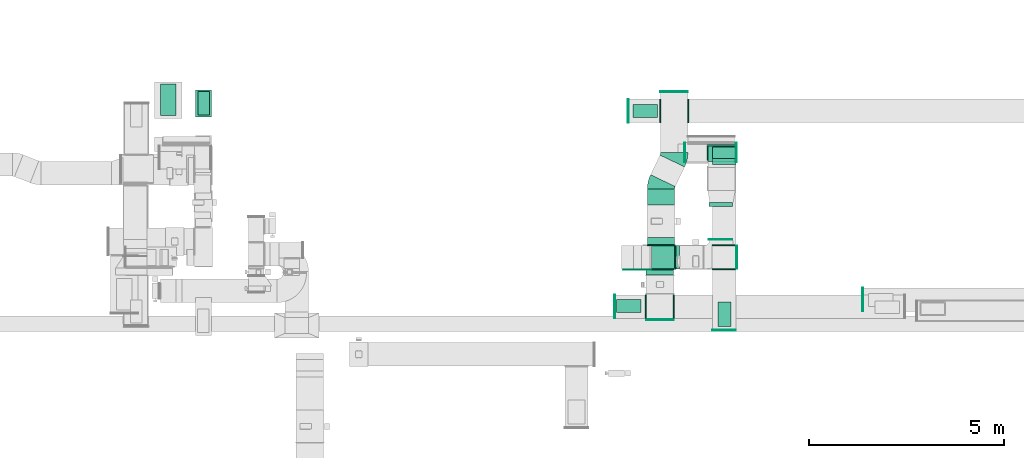
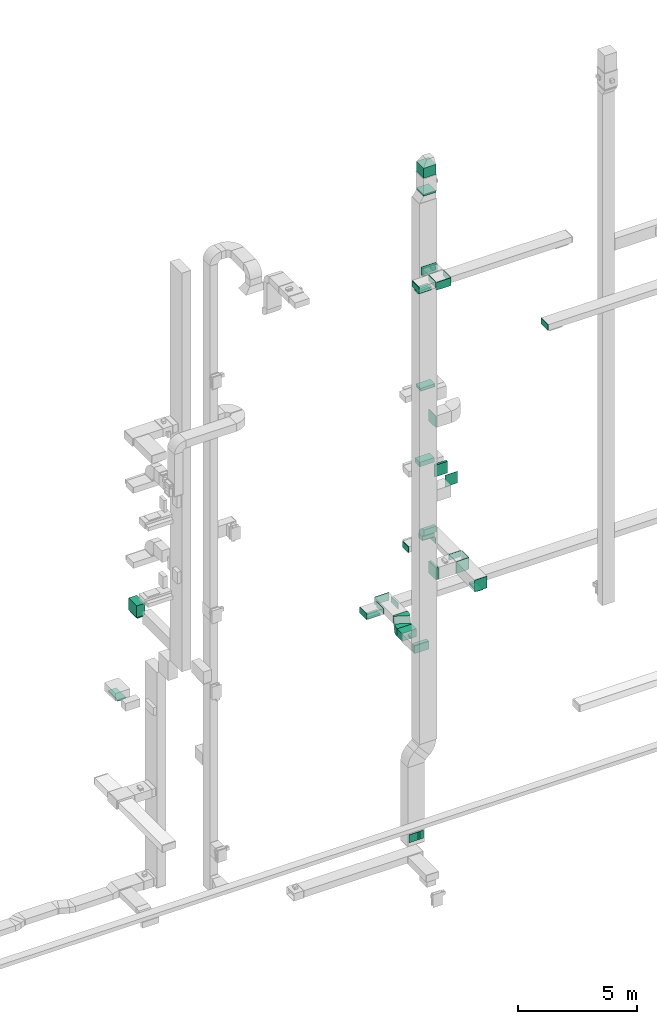
# One storey, part 15 of 29: 29 flow fittings, 19 flow segments, 3 flow terminals.
"""IFC2X3 building model written with IfcOpenShell, lengths in millimetres."""

from ifc_helpers import new_model, entity, si_unit, converted_unit, derived_unit, direction, frame, frame_2d, origin, origin_2d_with_axis, place, context, subcontext, project, spatial, polyline, circle_curve, parameter, trimmed, segment, composite_curve, rectangle, outline, extrude, source, transform, mapped, material, type_object, type_shapes, element, save


model = new_model("IFC2X3")

# Units and contexts
model_context = context("Model", 3, precision=0.01, world=origin(), true_north=direction((6.12303176911189e-17, 1.0)))
body_context = subcontext(model_context, "Body", "Model", "MODEL_VIEW")
ifc_project = project(units=[si_unit("LENGTHUNIT", "METRE", prefix="MILLI"), si_unit("AREAUNIT", "SQUARE_METRE"), si_unit("VOLUMEUNIT", "CUBIC_METRE"), converted_unit("PLANEANGLEUNIT", "DEGREE", entity("IfcRatioMeasure", 0.0174532925199433), si_unit("PLANEANGLEUNIT", "RADIAN"), dimensions=[0, 0, 0, 0, 0, 0, 0]), si_unit("MASSUNIT", "GRAM", prefix="KILO"), derived_unit("MASSDENSITYUNIT", [(si_unit("MASSUNIT", "GRAM", prefix="KILO"), 1), (si_unit("LENGTHUNIT", "METRE"), -3)]), derived_unit("MOMENTOFINERTIAUNIT", [(si_unit("LENGTHUNIT", "METRE"), 4)]), si_unit("TIMEUNIT", "SECOND"), si_unit("FREQUENCYUNIT", "HERTZ"), si_unit("THERMODYNAMICTEMPERATUREUNIT", "DEGREE_CELSIUS"), derived_unit("THERMALTRANSMITTANCEUNIT", [(si_unit("MASSUNIT", "GRAM", prefix="KILO"), 1), (si_unit("THERMODYNAMICTEMPERATUREUNIT", "KELVIN"), -1), (si_unit("TIMEUNIT", "SECOND"), -3)]), derived_unit("VOLUMETRICFLOWRATEUNIT", [(si_unit("LENGTHUNIT", "METRE"), 3), (si_unit("TIMEUNIT", "SECOND"), -1)]), derived_unit("MASSFLOWRATEUNIT", [(si_unit("MASSUNIT", "GRAM", prefix="KILO"), 1), (si_unit("TIMEUNIT", "SECOND"), -1)]), derived_unit("ROTATIONALFREQUENCYUNIT", [(si_unit("TIMEUNIT", "SECOND"), -1)]), si_unit("ELECTRICCURRENTUNIT", "AMPERE"), si_unit("ELECTRICVOLTAGEUNIT", "VOLT"), si_unit("POWERUNIT", "WATT"), si_unit("FORCEUNIT", "NEWTON", prefix="KILO"), si_unit("ILLUMINANCEUNIT", "LUX"), si_unit("LUMINOUSFLUXUNIT", "LUMEN"), si_unit("LUMINOUSINTENSITYUNIT", "CANDELA"), derived_unit("USERDEFINED", [(si_unit("MASSUNIT", "GRAM", prefix="KILO"), -1), (si_unit("LENGTHUNIT", "METRE"), -2), (si_unit("TIMEUNIT", "SECOND"), 3), (si_unit("LUMINOUSFLUXUNIT", "LUMEN"), 1)]), derived_unit("LINEARVELOCITYUNIT", [(si_unit("LENGTHUNIT", "METRE"), 1), (si_unit("TIMEUNIT", "SECOND"), -1)]), si_unit("PRESSUREUNIT", "PASCAL"), derived_unit("USERDEFINED", [(si_unit("LENGTHUNIT", "METRE"), -2), (si_unit("MASSUNIT", "GRAM", prefix="KILO"), 1), (si_unit("TIMEUNIT", "SECOND"), -2)]), derived_unit("LINEARFORCEUNIT", [(si_unit("MASSUNIT", "GRAM", prefix="KILO"), 1), (si_unit("LENGTHUNIT", "METRE"), 1), (si_unit("TIMEUNIT", "SECOND"), -2), (si_unit("LENGTHUNIT", "METRE"), -1)]), derived_unit("PLANARFORCEUNIT", [(si_unit("MASSUNIT", "GRAM", prefix="KILO"), 1), (si_unit("LENGTHUNIT", "METRE"), 1), (si_unit("TIMEUNIT", "SECOND"), -2), (si_unit("LENGTHUNIT", "METRE"), -2)])], contexts=[model_context])

# Site, building, storey
site_placement = place(None, frame((0.0, -0.00077364408347762, 0.0)))
site = spatial("IfcSite", under=ifc_project, at=site_placement, CompositionType="ELEMENT")
building_placement = place(site_placement, origin())
building = spatial("IfcBuilding", under=site, at=building_placement, CompositionType="ELEMENT")
storey_placement = place(building_placement, origin())
storey = spatial("IfcBuildingStorey", under=building, at=storey_placement, CompositionType="ELEMENT", Elevation=0.0)

# Flow segments
duct_segment_type = type_object("IfcDuctSegmentType", PredefinedType="NOTDEFINED")
flow_segment_1_placement = place(storey_placement, frame((30320.0012184742, 14480.2990914305, 10600.0)))
element("IfcFlowSegment", 1, at=flow_segment_1_placement, inside=storey, type_object=duct_segment_type, context=body_context, shape_type="SweptSolid", body=[
    extrude(rectangle(XDim=684.026141353115, YDim=400.0, at=frame_2d((0.0, -2.17426077142591e-12), x_axis=(1.0, 0.0))), frame((200.0, 342.013070676557, 0.0), z_axis=(0.0, 0.0, 1.0), x_axis=(0.0, 1.0, 0.0)), (0.0, 0.0, 1.0), 600.000000000002),
])
flow_segment_2_placement = place(storey_placement, frame((30375.0012184742, 14530.3252327836, 10500.0)))
element("IfcFlowSegment", 2, at=flow_segment_2_placement, inside=storey, type_object=duct_segment_type, context=body_context, shape_type="SweptSolid", body=[
    extrude(rectangle(XDim=300.000000000001, YDim=600.0, at=origin_2d_with_axis()), frame((150.0, 300.0, 0.0), z_axis=(0.0, 0.0, 1.0), x_axis=(-1.0, 0.0, 0.0)), (0.0, 0.0, 1.0), 79.9999999999861),
])
flow_segment_3_placement = place(storey_placement, frame((29421.0506788633, 14519.7082537764, 6600.0)))
element("IfcFlowSegment", 3, at=flow_segment_3_placement, inside=storey, type_object=duct_segment_type, context=body_context, shape_type="SweptSolid", body=[
    extrude(rectangle(XDim=800.0, YDim=400.0, at=frame_2d((0.0, -4.33431068813661e-12), x_axis=(1.0, 0.0))), frame((200.0, 400.0, 0.0), z_axis=(0.0, 0.0, 1.0), x_axis=(0.0, 1.0, 0.0)), (0.0, 0.0, 1.0), 79.999999999997),
])
flow_segment_4_placement = place(storey_placement, frame((41854.8655210282, 10425.5009107234, 26500.0)))
element("IfcFlowSegment", 4, at=flow_segment_4_placement, inside=storey, type_object=duct_segment_type, context=body_context, shape_type="SweptSolid", body=[
    extrude(rectangle(XDim=139.488841597194, YDim=699.999999999997, at=origin_2d_with_axis()), frame((350.0, 69.7444207985969, 0.0), z_axis=(0.0, 0.0, 1.0), x_axis=(0.0, 1.0, 0.0)), (0.0, 0.0, 1.0), 400.000000000004),
])
flow_segment_5_placement = place(storey_placement, frame((43430.5398916592, 13337.489106061, 18320.0)))
element("IfcFlowSegment", 5, at=flow_segment_5_placement, inside=storey, type_object=duct_segment_type, context=body_context, shape_type="SweptSolid", body=[
    extrude(rectangle(XDim=699.999999999997, YDim=400.0, at=origin_2d_with_axis()), frame((350.0, 200.0, 0.0)), (0.0, 0.0, 1.0), 130.00000000002),
])
flow_segment_6_placement = place(storey_placement, frame((43410.2593646877, 13367.4891060586, 14420.0)))
element("IfcFlowSegment", 6, at=flow_segment_6_placement, inside=storey, type_object=duct_segment_type, context=body_context, shape_type="SweptSolid", body=[
    extrude(rectangle(XDim=699.999999999997, YDim=400.0, at=frame_2d((0.0, -2.17426077142591e-12), x_axis=(1.0, 0.0))), frame((350.0, 200.0, 0.0)), (0.0, 0.0, 1.0), 230.00000000003),
])
flow_segment_7_placement = place(storey_placement, frame((43550.0749901644, 13410.0, 10570.0)))
element("IfcFlowSegment", 7, at=flow_segment_7_placement, inside=storey, type_object=duct_segment_type, context=body_context, shape_type="SweptSolid", body=[
    extrude(rectangle(XDim=600.0, YDim=299.999999999999, at=frame_2d((0.0, -1.08002495835535e-12), x_axis=(1.0, 0.0))), frame((299.99981860166, 150.0, 0.329907519098026), z_axis=(0.00109969173031232, 0.0, 0.999999395338866), x_axis=(0.999999395338866, 0.0, -0.00109969173031232)), (0.0, 0.0, 1.0), 179.670394612185),
])
flow_segment_8_placement = place(storey_placement, frame((41883.5613373781, 12228.4186270322, 6700.0)))
element("IfcFlowSegment", 8, at=flow_segment_8_placement, inside=storey, type_object=duct_segment_type, context=body_context, shape_type="SweptSolid", body=[
    extrude(rectangle(XDim=403.428874711334, YDim=699.999999999997, at=frame_2d((0.0, -4.32009983342141e-12), x_axis=(1.0, 0.0))), frame((350.0, 201.714437355674, 0.0), z_axis=(0.0, 0.0, 1.0), x_axis=(0.0, 1.0, 0.0)), (0.0, 0.0, 1.0), 400.0),
])
flow_segment_9_placement = place(storey_placement, frame((41520.6084914104, 14467.5650450043, 6600.0)))
element("IfcFlowSegment", 9, at=flow_segment_9_placement, inside=storey, type_object=duct_segment_type, context=body_context, shape_type="SweptSolid", body=[
    extrude(rectangle(XDim=624.999999999996, YDim=325.0, at=origin_2d_with_axis()), frame((312.499999999998, 162.500000000002, 0.0), z_axis=(0.0, 0.0, 1.0), x_axis=(-1.0, 0.0, 0.0)), (0.0, 0.0, 1.0), 79.9999999999991),
])
flow_segment_10_placement = place(storey_placement, frame((41883.5613373781, 11204.9897523208, 6700.0)))
element("IfcFlowSegment", 10, at=flow_segment_10_placement, inside=storey, type_object=duct_segment_type, context=body_context, shape_type="SweptSolid", body=[
    extrude(rectangle(XDim=183.428874711328, YDim=699.999999999997, at=frame_2d((0.0, -4.32009983342141e-12), x_axis=(1.0, 0.0))), frame((350.0, 91.7144373556814, 0.0), z_axis=(0.0, 0.0, 1.0), x_axis=(0.0, 1.0, 0.0)), (0.0, 0.0, 1.0), 400.0),
])
flow_segment_11_placement = place(storey_placement, frame((41268.8758486082, 10563.8395355731, -2400.0)))
element("IfcFlowSegment", 11, at=flow_segment_11_placement, inside=storey, type_object=duct_segment_type, context=body_context, shape_type="SweptSolid", body=[
    extrude(rectangle(XDim=5.00002860190674, YDim=700.000000000001, at=frame_2d((-1.08291153821938e-12, -2.8421709430404e-14), x_axis=(1.0, 0.0))), frame((350.006325877861, 3.65021754558849, 0.0), z_axis=(0.0, 0.0, 1.0), x_axis=(0.00328633355638581, 0.999994599991298, 0.0)), (0.0, 0.0, 1.0), 400.0),
])
flow_segment_12_placement = place(storey_placement, frame((42604.8655138023, 10584.9897523207, 10600.0)))
element("IfcFlowSegment", 12, at=flow_segment_12_placement, inside=storey, type_object=duct_segment_type, context=body_context, shape_type="SweptSolid", body=[
    extrude(rectangle(XDim=98.1044245040379, YDim=600.0, at=frame_2d((4.33075797445781e-12, -1.08002495835535e-12), x_axis=(1.0, 0.0))), frame((49.0522122520233, 300.0, 0.0)), (0.0, 0.0, 1.0), 599.999999999998),
])
flow_segment_13_placement = place(storey_placement, frame((43698.1022983322, 9112.79107497563, 10500.0)))
element("IfcFlowSegment", 13, at=flow_segment_13_placement, inside=storey, type_object=duct_segment_type, context=body_context, shape_type="SweptSolid", body=[
    extrude(rectangle(XDim=324.999999999995, YDim=625.0, at=frame_2d((0.0, 5.40012479177676e-13), x_axis=(1.0, 0.0))), frame((162.500000000006, 312.500000000006, 0.0), z_axis=(0.0, 0.0, 1.0), x_axis=(-1.0, 0.0, 0.0)), (0.0, 0.0, 1.0), 79.9999999999948),
])
flow_segment_14_placement = place(storey_placement, frame((41091.3824463804, 9472.09995962834, 26450.0)))
element("IfcFlowSegment", 14, at=flow_segment_14_placement, inside=storey, type_object=duct_segment_type, context=body_context, shape_type="SweptSolid", body=[
    extrude(rectangle(XDim=624.999999999996, YDim=325.0, at=origin_2d_with_axis()), frame((312.499999999998, 162.500000000013, 0.0)), (0.0, 0.0, 1.0), 129.999999999992),
])
flow_segment_15_placement = place(storey_placement, frame((41268.8907807506, 10563.7769857548, -2400.0)))
element("IfcFlowSegment", 15, at=flow_segment_15_placement, inside=storey, type_object=duct_segment_type, context=body_context, shape_type="SweptSolid", body=[
    extrude(rectangle(XDim=5.69002371007582, YDim=700.0, at=origin_2d_with_axis()), frame((350.003858851287, 3.36775948297264, 0.0), z_axis=(0.0, 0.0, 1.0), x_axis=(-0.00149357371773985, 0.999998884618153, 0.0)), (0.0, 0.0, 1.0), 400.0),
])
flow_segment_16_placement = place(storey_placement, frame((43460.2593646877, 12184.9897523207, 14600.0)))
element("IfcFlowSegment", 16, at=flow_segment_16_placement, inside=storey, type_object=duct_segment_type, context=body_context, shape_type="SweptSolid", body=[
    extrude(rectangle(XDim=100.000000000114, YDim=600.000000000002, at=frame_2d((1.08357767203415e-12, 0.0), x_axis=(1.0, 0.0))), frame((300.0, 50.0, 0.0), z_axis=(0.0, 0.0, 1.0), x_axis=(0.0, 1.0, 0.0)), (0.0, 0.0, 1.0), 600.000000000002),
])
flow_segment_17_placement = place(storey_placement, frame((43460.2593646877, 11334.989752321, 14600.0)))
element("IfcFlowSegment", 17, at=flow_segment_17_placement, inside=storey, type_object=duct_segment_type, context=body_context, shape_type="SweptSolid", body=[
    extrude(rectangle(XDim=9.99999999968153, YDim=600.000000000002, at=origin_2d_with_axis()), frame((300.0, 5.0, 0.0), z_axis=(0.0, 0.0, 1.0), x_axis=(0.0, -1.0, 0.0)), (0.0, 0.0, 1.0), 600.000000000002),
])
flow_segment_18_placement = place(storey_placement, frame((41984.8655138023, 10584.9897523208, 31398.9986172867)))
element("IfcFlowSegment", 18, at=flow_segment_18_placement, inside=storey, type_object=duct_segment_type, context=body_context, shape_type="SweptSolid", body=[
    extrude(rectangle(XDim=600.000000000002, YDim=600.0, at=frame_2d((0.0, -1.08002495835535e-12), x_axis=(1.0, 0.0))), frame((300.0, 300.0, 0.0)), (0.0, 0.0, 1.0), 510.622468051339),
])
flow_segment_19_placement = place(storey_placement, frame((41984.8655138023, 10584.9897523209, 30469.6210853374)))
element("IfcFlowSegment", 19, at=flow_segment_19_placement, inside=storey, type_object=duct_segment_type, context=body_context, shape_type="SweptSolid", body=[
    extrude(rectangle(XDim=600.000000000002, YDim=600.0, at=frame_2d((0.0, -1.08002495835535e-12), x_axis=(1.0, 0.0))), frame((300.0, 300.0, 0.0)), (0.0, 0.0, 1.0), 89.3775319488367),
])

# Flow fittings
ifc_material_1 = material()
duct_fitting_type_1 = type_object("IfcDuctFittingType", PredefinedType="NOTDEFINED", material=ifc_material_1)
shared_shape_1 = source(origin(), body_context, "Body", "SweptSolid", [
    extrude(rectangle(XDim=24.9999999999999, YDim=700.0, at=frame_2d((-2.89546164822241e-13, 5.6843418860808e-14), x_axis=(1.0, 0.0))), frame((12.500000000006, 0.0, -200.0)), (0.0, 0.0, 1.0), 400.0),
])
type_shapes(duct_fitting_type_1, [shared_shape_1])
for number, where, z_axis, x_axis in (
    (20, (42204.8655210282, 9297.2040104096, 26700.0), (0.0, 0.0, 1.0), (0.0, -1.0, 0.0)),
    (21, (42569.8464936403, 15105.1999990349, 6900.0), (0.0, 0.0, 1.0), (0.0, 1.0, 0.0)),
):
    element("IfcFlowFitting", number, at=place(storey_placement, frame(where, z_axis=z_axis, x_axis=x_axis)), inside=storey, type_object=duct_fitting_type_1, material=ifc_material_1, context=body_context, shape_type="MappedRepresentation", body=[
        mapped(shared_shape_1, transform((0.0, 0.0, 0.0), scale=1.0)),
    ])
duct_fitting_type_2 = type_object("IfcDuctFittingType", PredefinedType="NOTDEFINED", material=ifc_material_1)
shared_shape_2 = source(origin(), body_context, "Body", "SweptSolid", [
    extrude(rectangle(XDim=26.0960000000006, YDim=400.0, at=frame_2d((-3.10862446895044e-13, -1.4210854715202e-13), x_axis=(1.0, 0.0))), frame((6.95199999999999, 0.0, -350.0)), (0.0, 0.0, 1.0), 700.0),
])
type_shapes(duct_fitting_type_2, [shared_shape_2])
flow_fitting_1_placement = place(storey_placement, frame((42204.8655210282, 10584.9897523206, 26700.0), z_axis=(-1.0, 0.0, 0.0), x_axis=(0.0, -1.0, 0.0)))
element("IfcFlowFitting", 22, at=flow_fitting_1_placement, inside=storey, type_object=duct_fitting_type_2, material=ifc_material_1, context=body_context, shape_type="MappedRepresentation", body=[
    mapped(shared_shape_2, transform((0.0, 0.0, 0.0), scale=1.0)),
])
duct_fitting_type_3 = type_object("IfcDuctFittingType", PredefinedType="NOTDEFINED", material=ifc_material_1)
shared_shape_3 = source(origin(), body_context, "Body", "SweptSolid", [
    extrude(rectangle(XDim=26.0960000000291, YDim=600.0, at=frame_2d((-4.67181848762266e-13, -1.4210854715202e-13), x_axis=(1.0, 0.0))), frame((6.95199999999891, 0.0, -150.0)), (0.0, 0.0, 1.0), 300.0),
])
type_shapes(duct_fitting_type_3, [shared_shape_3])
for number, where, z_axis, x_axis in (
    (23, (42219.8464936403, 14630.0650296545, 6850.0), (0.0, 0.0, -1.0), (-1.0, 0.0, 0.0)),
    (24, (41854.8655210282, 9619.58124580589, 26750.0), (0.0, 0.0, -1.0), (-1.0, 0.0, 0.0)),
):
    element("IfcFlowFitting", number, at=place(storey_placement, frame(where, z_axis=z_axis, x_axis=x_axis)), inside=storey, type_object=duct_fitting_type_3, material=ifc_material_1, context=body_context, shape_type="MappedRepresentation", body=[
        mapped(shared_shape_3, transform((0.0, 0.0, 0.0), scale=1.0)),
    ])
duct_fitting_type_4 = type_object("IfcDuctFittingType", PredefinedType="NOTDEFINED", material=ifc_material_1)
shared_shape_4 = source(origin(), body_context, "Body", "SweptSolid", [
    extrude(rectangle(XDim=24.9999999999999, YDim=600.0, at=frame_2d((-2.46913600676635e-13, 0.0), x_axis=(1.0, 0.0))), frame((12.500000000006, 0.0, -150.0)), (0.0, 0.0, 1.0), 300.0),
])
type_shapes(duct_fitting_type_4, [shared_shape_4])
for number, where, z_axis, x_axis in (
    (25, (47415.3424852346, 9799.95823987361, 22500.0), (0.0, 0.0, 1.0), (-1.0, 0.0, 0.0)),
    (26, (41055.983899498, 9619.58124580588, 26750.0), (0.0, 0.0, 1.0), (-1.0, 0.0, 0.0)),
    (27, (41411.7933143667, 14630.0650296545, 6850.0), (0.0, 0.0, 1.0), (-1.0, -3.66943403428464e-08, 0.0)),
):
    element("IfcFlowFitting", number, at=place(storey_placement, frame(where, z_axis=z_axis, x_axis=x_axis)), inside=storey, type_object=duct_fitting_type_4, material=ifc_material_1, context=body_context, shape_type="MappedRepresentation", body=[
        mapped(shared_shape_4, transform((0.0, 0.0, 0.0), scale=1.0)),
    ])
duct_fitting_type_5 = type_object("IfcDuctFittingType", PredefinedType="NOTDEFINED", material=ifc_material_1)
shared_shape_5 = source(origin(), body_context, "Body", "SweptSolid", [
    extrude(rectangle(XDim=600.0, YDim=26.0960000000493, at=origin_2d_with_axis()), frame((6.95199999999999, 0.0, -150.0), z_axis=(0.0, 0.0, 1.0), x_axis=(0.0, -1.0, 0.0)), (0.0, 0.0, 1.0), 300.0),
])
type_shapes(duct_fitting_type_5, [shared_shape_5])
for number, where, z_axis, x_axis in (
    (28, (43850.6022983323, 11184.9897523207, 11050.0), (0.0, 0.0, -1.0), (0.0, 1.0, 0.0)),
    (29, (42919.8464936403, 14630.0652551759, 6850.0), (0.0, 0.0, -1.0), (1.0, 0.0, 0.0)),
    (30, (42554.8655210282, 9619.58124580589, 26750.0), (0.0, 0.0, -1.0), (1.0, 0.0, 0.0)),
):
    element("IfcFlowFitting", number, at=place(storey_placement, frame(where, z_axis=z_axis, x_axis=x_axis)), inside=storey, type_object=duct_fitting_type_5, material=ifc_material_1, context=body_context, shape_type="MappedRepresentation", body=[
        mapped(shared_shape_5, transform((0.0, 0.0, 0.0), scale=1.0)),
    ])
duct_fitting_type_6 = type_object("IfcDuctFittingType", PredefinedType="NOTDEFINED", material=ifc_material_1)
shared_shape_6 = source(origin(), body_context, "Body", "SweptSolid", [
    extrude(rectangle(XDim=26.0960000000009, YDim=600.0, at=frame_2d((-4.66293670342566e-13, -1.4210854715202e-13), x_axis=(1.0, 0.0))), frame((6.95199999999999, 0.0, -300.0)), (0.0, 0.0, 1.0), 600.0),
])
type_shapes(duct_fitting_type_6, [shared_shape_6])
for number, where, z_axis, x_axis in (
    (31, (43850.6022983322, 10584.9897523207, 10900.0), (0.0, 0.0, -1.0), (0.0, -1.0, 0.0)),
    (32, (42584.8655138023, 10884.9897523207, 18700.0), (0.0, -1.0, 0.0), (1.0, 0.0, 0.0)),
):
    element("IfcFlowFitting", number, at=place(storey_placement, frame(where, z_axis=z_axis, x_axis=x_axis)), inside=storey, type_object=duct_fitting_type_6, material=ifc_material_1, context=body_context, shape_type="MappedRepresentation", body=[
        mapped(shared_shape_6, transform((0.0, 0.0, 0.0), scale=1.0)),
    ])
duct_fitting_type_7 = type_object("IfcDuctFittingType", PredefinedType="NOTDEFINED", material=ifc_material_1)
shared_shape_7 = source(origin(), body_context, "Body", "SweptSolid", [
    extrude(rectangle(XDim=600.0, YDim=26.0960000000043, at=origin_2d_with_axis()), frame((6.95199999999999, 0.0, -300.0), z_axis=(0.0, 0.0, 1.0), x_axis=(0.0, -1.0, 0.0)), (0.0, 0.0, 1.0), 600.0),
])
type_shapes(duct_fitting_type_7, [shared_shape_7])
flow_fitting_2_placement = place(storey_placement, frame((42584.8655138023, 10884.9897523207, 10900.0), z_axis=(0.0, -1.0, 0.0), x_axis=(1.0, 0.0, 0.0)))
element("IfcFlowFitting", 33, at=flow_fitting_2_placement, inside=storey, type_object=duct_fitting_type_7, material=ifc_material_1, context=body_context, shape_type="MappedRepresentation", body=[
    mapped(shared_shape_7, transform((0.0, 0.0, 0.0), scale=1.0)),
])
duct_fitting_type_8 = type_object("IfcDuctFittingType", PredefinedType="NOTDEFINED", material=ifc_material_1)
shared_shape_8 = source(origin(), body_context, "Body", "SweptSolid", [
    extrude(rectangle(XDim=24.9999999999999, YDim=600.0, at=frame_2d((-2.46913600676635e-13, 0.0), x_axis=(1.0, 0.0))), frame((12.500000000006, 0.0, -300.0)), (0.0, 0.0, 1.0), 600.0),
])
type_shapes(duct_fitting_type_8, [shared_shape_8])
flow_fitting_3_placement = place(storey_placement, frame((44164.8655138024, 10884.9897523207, 10900.0)))
element("IfcFlowFitting", 34, at=flow_fitting_3_placement, inside=storey, type_object=duct_fitting_type_8, material=ifc_material_1, context=body_context, shape_type="MappedRepresentation", body=[
    mapped(shared_shape_8, transform((0.0, 0.0, 0.0), scale=1.0)),
])
flow_fitting_4_placement = place(storey_placement, frame((43850.6022983323, 9032.79107497565, 10900.0), z_axis=(0.0, 0.0, 1.0), x_axis=(0.0, -1.0, 0.0)))
element("IfcFlowFitting", 35, at=flow_fitting_4_placement, inside=storey, type_object=duct_fitting_type_8, material=ifc_material_1, context=body_context, shape_type="MappedRepresentation", body=[
    mapped(shared_shape_8, transform((0.0, 0.0, 0.0), scale=1.0)),
])
duct_fitting_type_9 = type_object("IfcDuctFittingType", PredefinedType="NOTDEFINED", material=ifc_material_1)
shared_shape_9 = source(origin(), body_context, "Body", "SweptSolid", [
    extrude(rectangle(XDim=24.9999999999999, YDim=500.0, at=frame_2d((-2.06057393370429e-13, 0.0), x_axis=(1.0, 0.0))), frame((12.5000000000061, 0.0, -150.0)), (0.0, 0.0, 1.0), 300.0),
])
type_shapes(duct_fitting_type_9, [shared_shape_9])
flow_fitting_5_placement = place(storey_placement, frame((42847.6705642871, 13567.4891060585, 10400.0), z_axis=(0.0, 0.0, 1.0), x_axis=(-1.0, 0.0, 0.0)))
element("IfcFlowFitting", 36, at=flow_fitting_5_placement, inside=storey, type_object=duct_fitting_type_9, material=ifc_material_1, context=body_context, shape_type="MappedRepresentation", body=[
    mapped(shared_shape_9, transform((0.0, 0.0, 0.0), scale=1.0)),
])

# Flow terminals
ifc_material_2 = material()
air_terminal_type = type_object("IfcAirTerminalType", PredefinedType="NOTDEFINED", material=ifc_material_2)
shared_shape_10 = source(origin(), body_context, "Body", "SweptSolid", [
    extrude(rectangle(XDim=4.0, YDim=624.999999999999, at=origin_2d_with_axis()), frame((0.0, -2.0, -162.500000000002), z_axis=(0.0, 0.0, 1.0), x_axis=(0.0, 1.0, 0.0)), (0.0, 0.0, 1.0), 325.000000000005),
])
type_shapes(air_terminal_type, [shared_shape_10])
for number, where, z_axis, x_axis in (
    (37, (41403.8824463804, 9634.59995962836, 26450.0), (0.0, -1.0, 0.0), (1.0, 0.0, 0.0)),
    (38, (43860.6022983322, 9425.29107497564, 10500.0), (1.0, 0.0, 0.0), (0.0, 1.0, 0.0)),
    (39, (41833.1084914104, 14630.0650450043, 6600.0), (-3.66943403428464e-08, 1.0, 0.0), (-1.0, -3.66943403428464e-08, 0.0)),
):
    element("IfcFlowTerminal", number, at=place(storey_placement, frame(where, z_axis=z_axis, x_axis=x_axis)), inside=storey, type_object=air_terminal_type, material=ifc_material_2, context=body_context, shape_type="MappedRepresentation", body=[
        mapped(shared_shape_10, transform((0.0, 0.0, 0.0), scale=1.0)),
    ])

# Flow fittings
duct_fitting_type_10 = type_object("IfcDuctFittingType", PredefinedType="NOTDEFINED", material=ifc_material_1)
shared_shape_11 = source(origin(), body_context, "Body", "SweptSolid", [
    extrude(rectangle(XDim=26.096000000001, YDim=625.0, at=frame_2d((-4.86721773995669e-13, -8.5265128291212e-14), x_axis=(1.0, 0.0))), frame((6.95199999999999, 0.0, -162.5)), (0.0, 0.0, 1.0), 325.0),
])
type_shapes(duct_fitting_type_10, [shared_shape_11])
flow_fitting_6_placement = place(storey_placement, frame((41833.1084914104, 14630.0650450043, 6700.0), z_axis=(0.0, -1.0, 0.0), x_axis=(0.0, 0.0, -1.0)))
element("IfcFlowFitting", 40, at=flow_fitting_6_placement, inside=storey, type_object=duct_fitting_type_10, material=ifc_material_1, context=body_context, shape_type="MappedRepresentation", body=[
    mapped(shared_shape_11, transform((0.0, 0.0, 0.0), scale=1.0)),
])
duct_fitting_type_11 = type_object("IfcDuctFittingType", PredefinedType="NOTDEFINED", material=ifc_material_1)
shared_shape_12 = source(origin(), body_context, "Body", "SweptSolid", [
    extrude(rectangle(XDim=700.0, YDim=26.096, at=frame_2d((-5.6843418860808e-14, 0.0), x_axis=(1.0, 0.0))), frame((6.95199999999999, 0.0, -200.0), z_axis=(0.0, 0.0, 1.0), x_axis=(0.0, -1.0, 0.0)), (0.0, 0.0, 1.0), 400.0),
])
type_shapes(duct_fitting_type_11, [shared_shape_12])
flow_fitting_7_placement = place(storey_placement, frame((43780.5398916592, 13537.489106061, 18300.0), z_axis=(0.0, 1.0, 0.0), x_axis=(0.0, 0.0, 1.0)))
element("IfcFlowFitting", 41, at=flow_fitting_7_placement, inside=storey, type_object=duct_fitting_type_11, material=ifc_material_1, context=body_context, shape_type="MappedRepresentation", body=[
    mapped(shared_shape_12, transform((0.0, 0.0, 0.0), scale=1.0)),
])
duct_fitting_type_12 = type_object("IfcDuctFittingType", PredefinedType="NOTDEFINED", material=ifc_material_1)
shared_shape_13 = source(origin(), body_context, "Body", "SweptSolid", [
    extrude(outline(composite_curve([segment(polyline([(-300.0, -150.0), (0.0, -150.0)]), True, "CONTINUOUS"), segment(trimmed(circle_curve(frame_2d((150.0, -150.0), x_axis=(0.0, 1.0)), 150.0), [parameter(0.0)], [parameter(90.0)], True, "PARAMETER"), False, "CONTINUOUS"), segment(polyline([(150.0, 0.0), (150.0, 300.0)]), True, "CONTINUOUS"), segment(trimmed(circle_curve(frame_2d((150.0, -150.0), x_axis=(0.0, 1.0)), 450.0), [parameter(0.0)], [parameter(90.0000000000001)], True, "PARAMETER"), True, "CONTINUOUS")], self_intersect=False)), frame((-150.0, 150.0, -300.0), z_axis=(0.0, 0.0, 1.0), x_axis=(-1.0, 0.0, 0.0)), (0.0, 0.0, 1.0), 600.0),
])
type_shapes(duct_fitting_type_12, [shared_shape_13])
flow_fitting_8_placement = place(storey_placement, frame((43850.6022983323, 13560.0, 11050.0), z_axis=(-0.999999395338866, 0.0, 0.0010996917303188), x_axis=(0.0, 1.0, 0.0)))
element("IfcFlowFitting", 42, at=flow_fitting_8_placement, inside=storey, type_object=duct_fitting_type_12, material=ifc_material_1, context=body_context, shape_type="MappedRepresentation", body=[
    mapped(shared_shape_13, transform((0.0, 0.0, 0.0), scale=1.0)),
])
duct_fitting_type_13 = type_object("IfcDuctFittingType", PredefinedType="NOTDEFINED", material=ifc_material_1)
shared_shape_14 = source(origin(), body_context, "Body", "SweptSolid", [
    extrude(rectangle(XDim=600.0, YDim=26.755815437163, at=origin_2d_with_axis()), frame((6.95200000000539, 0.0, -150.0), z_axis=(0.0, 0.0, 1.0), x_axis=(0.0, -1.0, 0.0)), (0.0, 0.0, 1.0), 300.0),
])
type_shapes(duct_fitting_type_13, [shared_shape_14])
flow_fitting_9_placement = place(storey_placement, frame((43850.0524521346, 13560.0, 10550.0), z_axis=(0.0, 1.0, 0.0), x_axis=(0.00109969173036458, 0.0, 0.999999395338866)))
element("IfcFlowFitting", 43, at=flow_fitting_9_placement, inside=storey, type_object=duct_fitting_type_13, material=ifc_material_1, context=body_context, shape_type="MappedRepresentation", body=[
    mapped(shared_shape_14, transform((0.0, 0.0, 0.0), scale=1.0)),
])
duct_fitting_type_14 = type_object("IfcDuctFittingType", PredefinedType="NOTDEFINED", material=ifc_material_1)
shared_shape_15 = source(origin(), body_context, "Body", "SweptSolid", [
    extrude(rectangle(XDim=24.9999999999999, YDim=300.0, at=frame_2d((-1.25233157177718e-13, 1.4210854715202e-14), x_axis=(1.0, 0.0))), frame((12.5000000000061, 0.0, -250.0)), (0.0, 0.0, 1.0), 500.0),
])
type_shapes(duct_fitting_type_14, [shared_shape_15])
flow_fitting_10_placement = place(storey_placement, frame((44147.670564287, 13567.4891060585, 10400.0), z_axis=(0.0, 1.0, 0.0), x_axis=(1.0, 0.0, 0.0)))
element("IfcFlowFitting", 44, at=flow_fitting_10_placement, inside=storey, type_object=duct_fitting_type_14, material=ifc_material_1, context=body_context, shape_type="MappedRepresentation", body=[
    mapped(shared_shape_15, transform((0.0, 0.0, 0.0), scale=1.0)),
])
duct_fitting_type_15 = type_object("IfcDuctFittingType", PredefinedType="NOTDEFINED", material=ifc_material_1)
shared_shape_16 = source(origin(), body_context, "Body", "SweptSolid", [
    extrude(rectangle(XDim=400.0, YDim=26.0960000000043, at=origin_2d_with_axis()), frame((6.95199999999999, 0.0, -350.0), z_axis=(0.0, 0.0, 1.0), x_axis=(0.0, -1.0, 0.0)), (0.0, 0.0, 1.0), 700.0),
])
type_shapes(duct_fitting_type_15, [shared_shape_16])
flow_fitting_11_placement = place(storey_placement, frame((42233.5613373781, 11184.9897523208, 6900.0), z_axis=(1.0, 0.0, 0.0), x_axis=(0.0, 1.0, 0.0)))
element("IfcFlowFitting", 45, at=flow_fitting_11_placement, inside=storey, type_object=duct_fitting_type_15, material=ifc_material_1, context=body_context, shape_type="MappedRepresentation", body=[
    mapped(shared_shape_16, transform((0.0, 0.0, 0.0), scale=1.0)),
])
duct_fitting_type_16 = type_object("IfcDuctFittingType", PredefinedType="NOTDEFINED", material=ifc_material_1)
shared_shape_17 = source(origin(), body_context, "Body", "SweptSolid", [
    extrude(outline(composite_curve([segment(polyline([(-374.355235787058, -107.631038196636), (325.644764212942, -107.631038196636)]), True, "CONTINUOUS"), segment(trimmed(circle_curve(frame_2d((475.644764212942, -107.631038196636), x_axis=(-0.902579056851767, 0.430524152786546)), 150.0), [parameter(0.0)], [parameter(25.5008287915224)], True, "PARAMETER"), False, "CONTINUOUS"), segment(polyline([(340.257905685177, -43.0524152786545), (-291.547434111061, 258.314491671928)]), True, "CONTINUOUS"), segment(trimmed(circle_curve(frame_2d((475.644764212942, -107.631038196636), x_axis=(-0.902579056851767, 0.430524152786546)), 850.0), [parameter(0.0)], [parameter(25.5008287915224)], True, "PARAMETER"), True, "CONTINUOUS")], self_intersect=False)), frame((-5.51121238056616, 24.3552357870499, -200.0), z_axis=(0.0, 0.0, 1.0), x_axis=(-0.430524152786547, 0.902579056851767, 0.0)), (0.0, 0.0, 1.0), 400.0),
])
type_shapes(duct_fitting_type_16, [shared_shape_17])
for number, where, z_axis, x_axis in (
    (46, (42233.5613373781, 12744.9897523207, 6900.0), (0.0, 0.0, 1.0), (-0.430524152786547, -0.902579056851767, 0.0)),
    (47, (42569.8464936404, 13450.0, 6900.0), (0.0, 0.0, 1.0), (0.430524152786562, 0.90257905685176, 0.0)),
):
    element("IfcFlowFitting", number, at=place(storey_placement, frame(where, z_axis=z_axis, x_axis=x_axis)), inside=storey, type_object=duct_fitting_type_16, material=ifc_material_1, context=body_context, shape_type="MappedRepresentation", body=[
        mapped(shared_shape_17, transform((0.0, 0.0, 0.0), scale=1.0)),
    ])
duct_fitting_type_17 = type_object("IfcDuctFittingType", PredefinedType="NOTDEFINED", material=ifc_material_1)
shared_shape_18 = source(origin(), body_context, "Body", "SweptSolid", [
    extrude(rectangle(XDim=625.0, YDim=26.0960000000195, at=frame_2d((-5.6843418860808e-14, 0.0), x_axis=(1.0, 0.0))), frame((6.95199999999999, 0.0, -162.5), z_axis=(0.0, 0.0, 1.0), x_axis=(0.0, -1.0, 0.0)), (0.0, 0.0, 1.0), 325.0),
])
type_shapes(duct_fitting_type_17, [shared_shape_18])
flow_fitting_12_placement = place(storey_placement, frame((41403.8824463804, 9634.59995962834, 26600.0), z_axis=(0.0, 1.0, 0.0), x_axis=(0.0, 0.0, -1.0)))
element("IfcFlowFitting", 48, at=flow_fitting_12_placement, inside=storey, type_object=duct_fitting_type_17, material=ifc_material_1, context=body_context, shape_type="MappedRepresentation", body=[
    mapped(shared_shape_18, transform((0.0, 0.0, 0.0), scale=1.0)),
])
duct_fitting_type_18 = type_object("IfcDuctFittingType", PredefinedType="NOTDEFINED", material=ifc_material_1)
shared_shape_19 = source(origin(), body_context, "Body", "SweptSolid", [
    extrude(rectangle(XDim=27.4762674883189, YDim=400.0, at=frame_2d((-3.10862446895044e-13, -1.4210854715202e-13), x_axis=(1.0, 0.0))), frame((6.95199999999488, 0.0, -350.0)), (0.0, 0.0, 1.0), 700.0),
])
type_shapes(duct_fitting_type_18, [shared_shape_19])
flow_fitting_13_placement = place(storey_placement, frame((41618.9791218452, 10584.9897523178, -2200.0), z_axis=(-1.0, 0.0, 0.0), x_axis=(0.0, -1.0, 0.0)))
element("IfcFlowFitting", 49, at=flow_fitting_13_placement, inside=storey, type_object=duct_fitting_type_18, material=ifc_material_1, context=body_context, shape_type="MappedRepresentation", body=[
    mapped(shared_shape_19, transform((0.0, 0.0, 0.0), scale=1.0)),
])
duct_fitting_type_19 = type_object("IfcDuctFittingType", PredefinedType="NOTDEFINED", material=ifc_material_1)
shared_shape_20 = source(origin(), body_context, "Body", "SweptSolid", [
    extrude(rectangle(XDim=325.0, YDim=26.0960000000043, at=origin_2d_with_axis()), frame((6.95199999999999, 0.0, -312.5), z_axis=(0.0, 0.0, 1.0), x_axis=(0.0, -1.0, 0.0)), (0.0, 0.0, 1.0), 625.0),
])
type_shapes(duct_fitting_type_19, [shared_shape_20])
flow_fitting_14_placement = place(storey_placement, frame((43860.6022983322, 9425.29107497564, 10600.0), z_axis=(0.0, -1.0, 0.0), x_axis=(0.0, 0.0, -1.0)))
element("IfcFlowFitting", 50, at=flow_fitting_14_placement, inside=storey, type_object=duct_fitting_type_19, material=ifc_material_1, context=body_context, shape_type="MappedRepresentation", body=[
    mapped(shared_shape_20, transform((0.0, 0.0, 0.0), scale=1.0)),
])
duct_fitting_type_20 = type_object("IfcDuctFittingType", PredefinedType="NOTDEFINED", material=ifc_material_1)
shared_shape_21 = source(origin(), body_context, "Body", "SweptSolid", [
    extrude(rectangle(XDim=26.0960000000719, YDim=300.0, at=frame_2d((-2.32702745961433e-13, -9.9475983006414e-14), x_axis=(1.0, 0.0))), frame((6.95200000000324, 0.0, -300.0)), (0.0, 0.0, 1.0), 600.0),
])
type_shapes(duct_fitting_type_20, [shared_shape_21])
flow_fitting_15_placement = place(storey_placement, frame((42184.8655138023, 10584.9897523206, 26750.0), z_axis=(-1.0, 0.0, 0.0), x_axis=(0.0, -1.0, 0.0)))
element("IfcFlowFitting", 51, at=flow_fitting_15_placement, inside=storey, type_object=duct_fitting_type_20, material=ifc_material_1, context=body_context, shape_type="MappedRepresentation", body=[
    mapped(shared_shape_21, transform((0.0, 0.0, 0.0), scale=1.0)),
])

save(model, "model.ifc")
